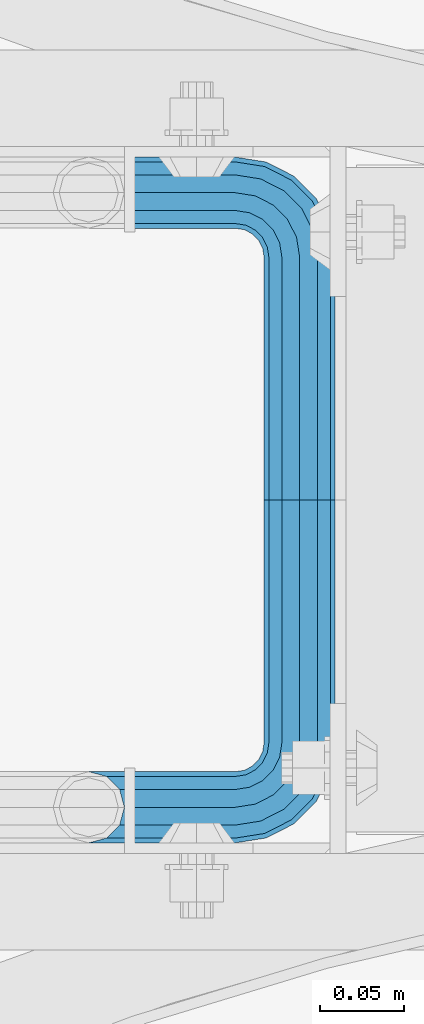
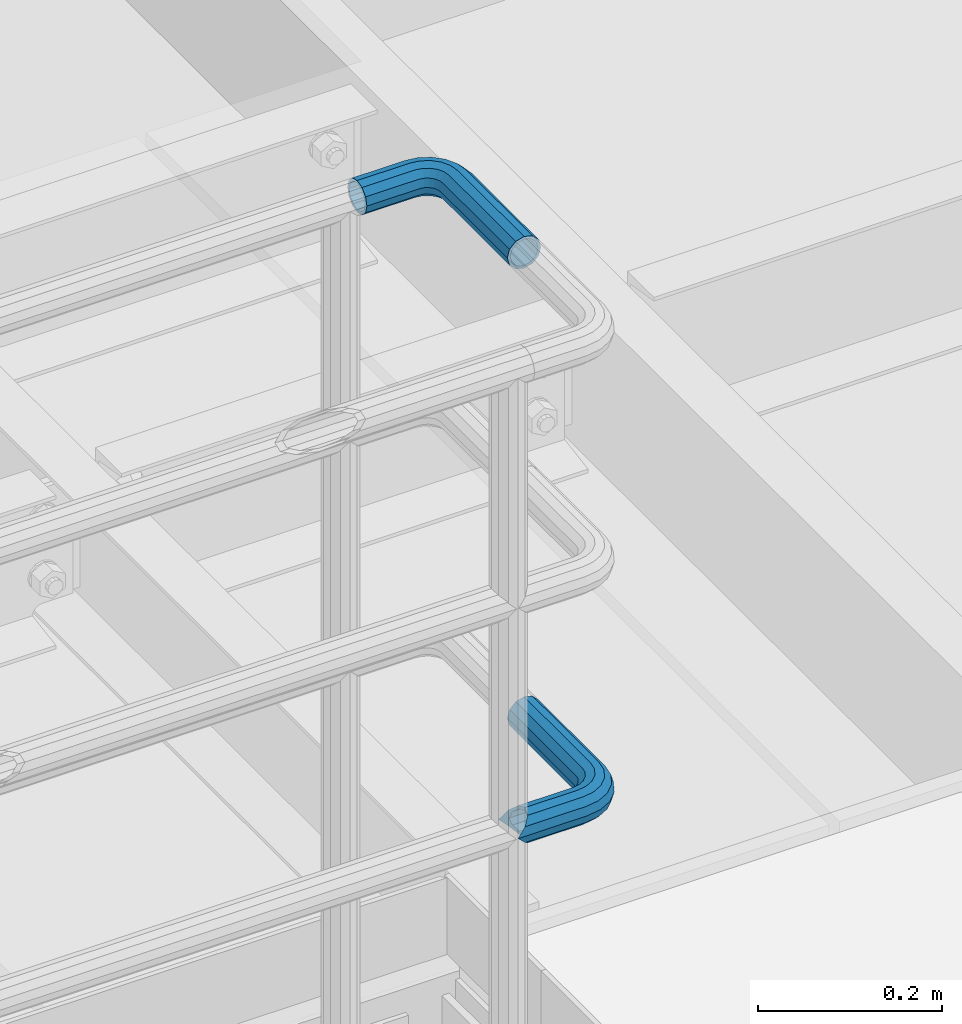
# One storey, part 1113 of 1876: 2 beams, 2 elements without a shape of their own.
"""IFC2X3 building model written with IfcOpenShell, lengths in millimetres."""

from ifc_helpers import new_model, si_unit, frame, origin_with_axes, place, context, subcontext, project, spatial, faceted_brep, material, type_object, element, aggregate, save


model = new_model("IFC2X3")

# Units and contexts
model_context = context("Model", 3, precision=1e-05, world=origin_with_axes())
body_context = subcontext(model_context, "Body", "Model", "MODEL_VIEW")
ifc_project = project(units=[si_unit("LENGTHUNIT", "METRE", prefix="MILLI"), si_unit("AREAUNIT", "SQUARE_METRE"), si_unit("VOLUMEUNIT", "CUBIC_METRE"), si_unit("MASSUNIT", "GRAM", prefix="KILO"), si_unit("TIMEUNIT", "SECOND"), si_unit("PLANEANGLEUNIT", "RADIAN"), si_unit("SOLIDANGLEUNIT", "STERADIAN"), si_unit("THERMODYNAMICTEMPERATUREUNIT", "DEGREE_CELSIUS"), si_unit("LUMINOUSINTENSITYUNIT", "LUMEN")], contexts=[model_context])

# Site, building, storey
site_placement = place(None, origin_with_axes())
site = spatial("IfcSite", under=ifc_project, at=site_placement, CompositionType="ELEMENT")
building_placement = place(site_placement, origin_with_axes())
building = spatial("IfcBuilding", under=site, at=building_placement, Name="Undefined", CompositionType="ELEMENT")
storey_placement = place(building_placement, origin_with_axes())
storey = spatial("IfcBuildingStorey", under=building, at=storey_placement, Name="Undefined", CompositionType="ELEMENT", Elevation=0.0)

# Assembly, beam
assembly_1_placement = place(storey_placement, origin_with_axes())
assembly_1 = element("IfcElementAssembly", 1, at=assembly_1_placement, inside=storey, Name="HANDRAIL", AssemblyPlace="NOTDEFINED", PredefinedType="RIGID_FRAME")
ifc_material = material()
beam_type = type_object("IfcBeamType", Name="PIPE1-1/4STD", PredefinedType="NOTDEFINED")
beam_1_placement = place(assembly_1_placement, frame((4696.96656849878, -11563.3144042962, 9090.025), z_axis=(0.0, 0.0, -1.0), x_axis=(0.0, 1.0, 0.0)))
beam_1 = element("IfcBeam", 2, at=beam_1_placement, type_object=beam_type, material=ifc_material, Name="HANDRAIL", ObjectType="PIPE1-1/4STD", context=body_context, shape_type="Brep", body=[
    faceted_brep([(9.09494701772928e-13, -21.0820000000003, 0.0), (0.0, -18.2575475625836, -10.5409999999993), (143.946846008301, -18.2575475625854, -10.5409999999993), (143.946846008301, -21.0820000000012, 0.0), (0.0, -10.5410000000002, -18.2575475625836), (143.946846008301, -10.5410000000011, -18.2575475625836), (-4.28826751885936e-09, 0.0, -21.0820000000003), (143.946846008301, -1.81898940354586e-12, -21.0820000000003), (0.0, 10.5410000000002, -18.2575475625836), (143.946846008301, 10.5409999999983, -18.2575475625836), (0.0, 18.2575475625836, -10.5409999999993), (143.946846008301, 18.2575475625817, -10.5409999999993), (9.09494701772928e-13, 21.0820000000003, 0.0), (143.946846008301, 21.0819999999985, 0.0), (0.0, 18.2575475625836, 10.5409999999993), (143.946846008301, 18.2575475625817, 10.5409999999993), (0.0, 10.5410000000002, 18.2575475625836), (143.946846008301, 10.5409999999983, 18.2575475625836), (0.0, 0.0, 21.0820000000003), (143.946846008301, -1.81898940354586e-12, 21.0820000000003), (0.0, -10.5410000000002, 18.2575475625836), (143.946846008301, -10.5410000000011, 18.2575475625836), (0.0, -18.2575475625836, 10.5409999999993), (143.946846008301, -18.2575475625854, 10.5409999999993), (0.0, -17.5259999999998, 0.0), (0.0, -15.1779612267264, 8.76300000000083), (143.946846008301, -15.1779612267273, 8.76300000000083), (143.946846008301, -17.5260000000017, 0.0), (0.0, -8.76299999999992, 15.1779612267255), (143.946846008301, -8.76300000000174, 15.1779612267255), (0.0, 0.0, 17.5259999999998), (143.946846008301, -1.81898940354586e-12, 17.5259999999998), (0.0, 8.76299999999992, 15.1779612267255), (143.946846008301, 8.76299999999901, 15.1779612267255), (0.0, 15.1779612267264, 8.76300000000083), (143.946846008301, 15.1779612267246, 8.76300000000083), (0.0, 17.5259999999998, 0.0), (143.946846008301, 17.5259999999989, 0.0), (0.0, 15.1779612267264, -8.76300000000083), (143.946846008301, 15.1779612267246, -8.76300000000083), (0.0, 8.76299999999992, -15.1779612267255), (143.946846008301, 8.76299999999901, -15.1779612267255), (0.0, 0.0, -17.5259999999998), (143.946846008301, -1.81898940354586e-12, -17.5259999999998), (0.0, -8.76299999999992, -15.1779612267255), (143.946846008301, -8.76300000000174, -15.1779612267255), (0.0, -15.1779612267264, -8.76300000000083), (143.946846008301, -15.1779612267273, -8.76300000000083), (149.205696747053, -21.9149201310092, 0.0), (150.078500550018, -19.2287062354389, 10.5409999999993), (152.46304488476, -11.8898333927427, 18.2575475625836), (155.720393022468, -1.86474665447531, 21.0820000000003), (158.977741160175, 8.1603400837912, 18.2575475625836), (161.362285494917, 15.4992129264883, 10.5409999999993), (162.235089297883, 18.1854268220586, 0.0), (161.362285494917, 15.4992129264883, -10.5409999999993), (158.977741160175, 8.1603400837912, -18.2575475625836), (155.720393022468, -1.86474665447531, -21.0820000000003), (152.46304488476, -11.8898333927427, -18.2575475625836), (150.078500550018, -19.2287062354389, -10.5409999999993), (161.136224865884, 14.8034698501133, 0.0), (160.410640981492, 12.570352274277, 8.76300000000083), (158.428308944176, 6.46936159781853, 15.1779612267255), (155.720393022468, -1.86474665447531, 17.5259999999998), (153.012477100759, -10.1988549067692, 15.1779612267255), (151.030145063443, -16.2998455832276, 8.76300000000083), (150.304561179051, -18.5329631590639, 0.0), (151.030145063443, -16.2998455832276, -8.76300000000083), (153.012477100759, -10.1988549067692, -15.1779612267255), (155.720393022468, -1.86474665447531, -17.5259999999998), (158.428308944176, 6.46936159781853, -15.1779612267255), (160.410640981492, 12.570352274277, -8.76300000000083), (172.537307568173, 1.25139591480547, 18.2575475625836), (177.072980424075, 7.49421403083761, 10.5409999999993), (166.341463223758, -7.27645222290084, 21.0820000000003), (160.145618879342, -15.8043003606062, 18.2575475625836), (155.609946023442, -22.0471184766393, 10.5409999999993), (153.949774534927, -24.3321484983126, 0.0), (155.609946023442, -22.0471184766393, -10.5409999999993), (160.145618879342, -15.8043003606062, -18.2575475625836), (166.341463223758, -7.27645222290084, -21.0820000000003), (172.537307568173, 1.25139591480547, -18.2575475625836), (177.072980424075, 7.49421403083761, -10.5409999999993), (178.733151912589, 9.77924405251179, 0.0), (175.262844992696, 5.00277634948452, -8.76300000000083), (176.642987555437, 6.90237962051378, 0.0), (171.492225389597, -0.187036301193075, -15.1779612267255), (166.341463223758, -7.27645222290084, -17.5259999999998), (161.190701057918, -14.3658681446077, -15.1779612267255), (157.42008145482, -19.5556807952853, -8.76300000000083), (156.03993889208, -21.4552840663155, 0.0), (157.42008145482, -19.5556807952853, 8.76300000000083), (161.190701057918, -14.3658681446077, 15.1779612267255), (166.341463223758, -7.27645222290084, 17.5259999999998), (171.492225389597, -0.187036301193075, 15.1779612267255), (175.262844992696, 5.00277634948452, 8.76300000000083), (183.298240397229, -9.50953691424911, 18.2575475625836), (189.541058513261, -4.97386405834823, 10.5409999999993), (174.770392259523, -15.7053812586646, 21.0820000000003), (166.242544121817, -21.901225603081, 18.2575475625836), (159.999726005784, -26.4368984589819, 10.5409999999993), (157.714695984112, -28.0970699474974, 0.0), (159.999726005784, -26.4368984589819, -10.5409999999993), (166.242544121817, -21.901225603081, -18.2575475625836), (174.770392259523, -15.7053812586646, -21.0820000000003), (183.298240397229, -9.50953691424911, -18.2575475625836), (189.541058513261, -4.97386405834823, -10.5409999999993), (191.826088534934, -3.31369256983271, 0.0), (187.049620831907, -6.78399948972674, -8.76300000000083), (188.949224102937, -5.4038569269851, 0.0), (181.859808181231, -10.5546190928253, -15.1779612267255), (174.770392259523, -15.7053812586646, -17.5259999999998), (167.680976337815, -20.8561434245048, -15.1779612267255), (162.491163687138, -24.6267630276034, -8.76300000000083), (160.591560416109, -26.006905590345, 0.0), (162.491163687138, -24.6267630276034, 8.76300000000083), (167.680976337815, -20.8561434245048, 15.1779612267255), (174.770392259523, -15.7053812586646, 17.5259999999998), (181.859808181231, -10.5546190928253, 15.1779612267255), (187.049620831907, -6.78399948972674, 8.76300000000083), (190.207184566216, -23.0691033222465, 18.2575475625836), (197.546057408912, -20.6845589875047, 10.5409999999993), (180.182097827948, -26.3264514599541, 21.0820000000003), (170.157011089683, -29.5837995976626, 18.2575475625836), (162.818138246987, -31.9683439324044, 10.5409999999993), (160.131924351415, -32.8411477353702, 0.0), (162.818138246987, -31.9683439324044, -10.5409999999993), (170.157011089683, -29.5837995976626, -18.2575475625836), (180.182097827948, -26.3264514599541, -21.0820000000003), (190.207184566216, -23.0691033222465, -18.2575475625836), (197.546057408912, -20.6845589875047, -10.5409999999993), (200.232271304483, -19.8117551845389, 0.0), (194.617196756701, -21.6362035009297, -8.76300000000083), (196.850314332538, -20.9106196165367, 0.0), (188.516206080243, -23.6185355382449, -15.1779612267255), (180.182097827948, -26.3264514599541, -17.5259999999998), (171.847989575655, -29.0343673816633, -15.1779612267255), (165.746998899196, -31.0166994189794, -8.76300000000083), (163.513881323361, -31.7422833033725, 0.0), (165.746998899196, -31.0166994189794, 8.76300000000083), (171.847989575655, -29.0343673816633, 15.1779612267255), (180.182097827948, -26.3264514599541, 17.5259999999998), (188.516206080243, -23.6185355382449, 15.1779612267255), (194.617196756701, -21.6362035009297, 8.76300000000083), (171.505844482424, -38.0999984741229, -18.2575475625836), (163.78929691984, -38.0999984741229, -10.5409999999993), (182.046844482424, -38.099998474122, -21.0820000000003), (192.587844482425, -38.099998474122, -18.2575475625836), (200.304392045007, -38.099998474122, -10.5409999999993), (203.128844482424, -38.099998474122, 0.0), (200.304392045007, -38.099998474122, 10.5409999999993), (192.587844482425, -38.099998474122, 18.2575475625836), (182.046844482424, -38.099998474122, 21.0820000000003), (171.505844482424, -38.0999984741229, 18.2575475625836), (163.78929691984, -38.0999984741229, 10.5409999999993), (160.964844482422, -38.0999984741229, 0.0), (197.224805709149, -38.099998474122, -8.76300000000083), (199.572844482424, -38.099998474122, 0.0), (190.809844482425, -38.099998474122, -15.1779612267255), (182.046844482424, -38.099998474122, -17.5259999999998), (173.283844482423, -38.099998474122, -15.1779612267255), (166.868883255698, -38.0999984741229, -8.76300000000083), (164.520844482422, -38.0999984741229, 0.0), (166.868883255698, -38.0999984741229, 8.76300000000083), (173.283844482423, -38.099998474122, 15.1779612267255), (182.046844482424, -38.099998474122, 17.5259999999998), (190.809844482425, -38.099998474122, 15.1779612267255), (197.224805709149, -38.099998474122, 8.76300000000083), (163.789296919838, -103.933624267578, -10.5409999999993), (160.964844482422, -103.933624267578, 0.0), (171.505844482423, -103.933624267578, -18.2575475625836), (182.046844482422, -103.933624267578, -21.0820000000003), (192.587844482421, -103.933624267578, -18.2575475625836), (200.304392045005, -103.933624267578, -10.5409999999993), (203.128844482422, -103.933624267578, 0.0), (200.304392045005, -103.933624267578, 10.5409999999993), (192.587844482421, -103.933624267578, 18.2575475625836), (182.046844482422, -103.933624267578, 21.0820000000003), (171.505844482423, -103.933624267578, 18.2575475625836), (163.789296919838, -103.933624267578, 10.5409999999993), (166.868883255696, -103.933624267578, 8.76300000000083), (164.520844482422, -103.933624267578, 0.0), (173.283844482421, -103.933624267578, 15.1779612267255), (182.046844482422, -103.933624267578, 17.5259999999998), (190.809844482423, -103.933624267578, 15.1779612267255), (197.224805709147, -103.933624267578, 8.76300000000083), (199.572844482422, -103.933624267578, 0.0), (197.224805709147, -103.933624267578, -8.76300000000083), (190.809844482423, -103.933624267578, -15.1779612267255), (182.046844482422, -103.933624267578, -17.5259999999998), (173.283844482421, -103.933624267578, -15.1779612267255), (166.868883255696, -103.933624267578, -8.76300000000083)], [[[0, 1, 2, 3]], [[1, 4, 5, 2]], [[4, 6, 7, 5]], [[6, 8, 9, 7]], [[8, 10, 11, 9]], [[10, 12, 13, 11]], [[12, 14, 15, 13]], [[14, 16, 17, 15]], [[16, 18, 19, 17]], [[18, 20, 21, 19]], [[20, 22, 23, 21]], [[22, 0, 3, 23]], [[24, 25, 26, 27]], [[25, 28, 29, 26]], [[28, 30, 31, 29]], [[30, 32, 33, 31]], [[32, 34, 35, 33]], [[34, 36, 37, 35]], [[36, 38, 39, 37]], [[38, 40, 41, 39]], [[40, 42, 43, 41]], [[42, 44, 45, 43]], [[44, 46, 47, 45]], [[46, 24, 27, 47]], [[22, 20, 18, 16, 14, 12, 10, 8, 6, 4, 1, 0], [46, 44, 42, 40, 38, 36, 34, 32, 30, 28, 25, 24]], [[23, 3, 48, 49]], [[21, 23, 49, 50]], [[19, 21, 50, 51]], [[17, 19, 51, 52]], [[15, 17, 52, 53]], [[13, 15, 53, 54]], [[11, 13, 54, 55]], [[9, 11, 55, 56]], [[7, 9, 56, 57]], [[5, 7, 57, 58]], [[2, 5, 58, 59]], [[3, 2, 59, 48]], [[35, 37, 60, 61]], [[33, 35, 61, 62]], [[31, 33, 62, 63]], [[29, 31, 63, 64]], [[26, 29, 64, 65]], [[27, 26, 65, 66]], [[47, 27, 66, 67]], [[45, 47, 67, 68]], [[43, 45, 68, 69]], [[41, 43, 69, 70]], [[39, 41, 70, 71]], [[37, 39, 71, 60]], [[52, 72, 73, 53]], [[51, 74, 72, 52]], [[50, 75, 74, 51]], [[49, 76, 75, 50]], [[48, 77, 76, 49]], [[59, 78, 77, 48]], [[58, 79, 78, 59]], [[57, 80, 79, 58]], [[56, 81, 80, 57]], [[55, 82, 81, 56]], [[54, 83, 82, 55]], [[53, 73, 83, 54]], [[71, 84, 85, 60]], [[70, 86, 84, 71]], [[69, 87, 86, 70]], [[68, 88, 87, 69]], [[67, 89, 88, 68]], [[66, 90, 89, 67]], [[65, 91, 90, 66]], [[64, 92, 91, 65]], [[63, 93, 92, 64]], [[62, 94, 93, 63]], [[61, 95, 94, 62]], [[60, 85, 95, 61]], [[72, 96, 97, 73]], [[74, 98, 96, 72]], [[75, 99, 98, 74]], [[76, 100, 99, 75]], [[77, 101, 100, 76]], [[78, 102, 101, 77]], [[79, 103, 102, 78]], [[80, 104, 103, 79]], [[81, 105, 104, 80]], [[82, 106, 105, 81]], [[83, 107, 106, 82]], [[73, 97, 107, 83]], [[84, 108, 109, 85]], [[86, 110, 108, 84]], [[87, 111, 110, 86]], [[88, 112, 111, 87]], [[89, 113, 112, 88]], [[90, 114, 113, 89]], [[91, 115, 114, 90]], [[92, 116, 115, 91]], [[93, 117, 116, 92]], [[94, 118, 117, 93]], [[95, 119, 118, 94]], [[85, 109, 119, 95]], [[96, 120, 121, 97]], [[98, 122, 120, 96]], [[99, 123, 122, 98]], [[100, 124, 123, 99]], [[101, 125, 124, 100]], [[102, 126, 125, 101]], [[103, 127, 126, 102]], [[104, 128, 127, 103]], [[105, 129, 128, 104]], [[106, 130, 129, 105]], [[107, 131, 130, 106]], [[97, 121, 131, 107]], [[108, 132, 133, 109]], [[110, 134, 132, 108]], [[111, 135, 134, 110]], [[112, 136, 135, 111]], [[113, 137, 136, 112]], [[114, 138, 137, 113]], [[115, 139, 138, 114]], [[116, 140, 139, 115]], [[117, 141, 140, 116]], [[118, 142, 141, 117]], [[119, 143, 142, 118]], [[109, 133, 143, 119]], [[127, 144, 145, 126]], [[128, 146, 144, 127]], [[129, 147, 146, 128]], [[130, 148, 147, 129]], [[131, 149, 148, 130]], [[121, 150, 149, 131]], [[120, 151, 150, 121]], [[122, 152, 151, 120]], [[123, 153, 152, 122]], [[124, 154, 153, 123]], [[125, 155, 154, 124]], [[126, 145, 155, 125]], [[132, 156, 157, 133]], [[134, 158, 156, 132]], [[135, 159, 158, 134]], [[136, 160, 159, 135]], [[137, 161, 160, 136]], [[138, 162, 161, 137]], [[139, 163, 162, 138]], [[140, 164, 163, 139]], [[141, 165, 164, 140]], [[142, 166, 165, 141]], [[143, 167, 166, 142]], [[133, 157, 167, 143]], [[155, 145, 168, 169]], [[145, 144, 170, 168]], [[144, 146, 171, 170]], [[146, 147, 172, 171]], [[147, 148, 173, 172]], [[148, 149, 174, 173]], [[149, 150, 175, 174]], [[150, 151, 176, 175]], [[151, 152, 177, 176]], [[152, 153, 178, 177]], [[153, 154, 179, 178]], [[154, 155, 169, 179]], [[162, 163, 180, 181]], [[163, 164, 182, 180]], [[164, 165, 183, 182]], [[165, 166, 184, 183]], [[166, 167, 185, 184]], [[167, 157, 186, 185]], [[157, 156, 187, 186]], [[156, 158, 188, 187]], [[158, 159, 189, 188]], [[159, 160, 190, 189]], [[160, 161, 191, 190]], [[161, 162, 181, 191]], [[170, 171, 172, 173, 174, 175, 176, 177, 178, 179, 169, 168], [182, 183, 184, 185, 186, 187, 188, 189, 190, 191, 181, 180]]]),
])
aggregate(assembly_1, [beam_1])

assembly_2_placement = place(storey_placement, origin_with_axes())
assembly_2 = element("IfcElementAssembly", 3, at=assembly_2_placement, inside=storey, Name="HANDRAIL", AssemblyPlace="NOTDEFINED", PredefinedType="RIGID_FRAME")
beam_2_placement = place(assembly_2_placement, frame((4696.96656849878, -11563.3144042962, 8480.425), z_axis=(0.0, 0.0, -1.0), x_axis=(0.0, -1.0, 0.0)))
beam_2 = element("IfcBeam", 4, at=beam_2_placement, type_object=beam_type, material=ifc_material, Name="HANDRAIL", ObjectType="PIPE1-1/4STD", context=body_context, shape_type="Brep", body=[
    faceted_brep([(192.659041992189, 106.710451704997, 18.2575475625836), (192.659048095087, 106.710451704997, 13.3999551238248), (190.881041992188, 106.234036405587, 15.1779612267255), (182.118041992188, 103.88599926758, 17.5259999999998), (182.118041992188, 103.88599926758, 21.0820000000003), (173.355041992188, 106.234039676121, 15.1779612267255), (171.577048095089, 106.710451704997, 13.3999673296257), (171.577041992188, 106.710451704997, 18.2575475625836), (163.860494429604, 114.42699926758, 10.5409999999993), (163.860494429604, 114.42699926758, -10.5409999999993), (161.036041992187, 124.968002319336, 0.0), (166.940080765462, 111.347419034623, 8.76300000000083), (164.592041992188, 113.695457807897, 0.0), (166.940080765462, 111.347419034623, -8.76300000000083), (171.577048095089, 106.710451704997, -13.3999673296257), (171.577041992188, 106.710451704997, -18.2575475625836), (182.118041992188, 103.88599926758, -17.5259999999998), (182.118041992188, 103.88599926758, -21.0820000000003), (173.355041992188, 106.234039676121, -15.1779612267255), (192.659048095087, 106.710451704997, -13.3999551238248), (192.659041992189, 106.710451704997, -18.2575475625836), (190.881041992188, 106.234036405587, -15.1779612267255), (203.200048095088, 124.96799926758, 0.0), (200.375589554771, 114.42699926758, -10.5409999999993), (200.375589554771, 114.42699926758, 10.5409999999993), (197.296003218913, 111.347406828822, -8.76300000000083), (199.644041992187, 113.695445602096, 0.0), (197.296003218913, 111.347406828822, 8.76300000000083), (0.0, -18.2575475625836, -10.5409999999993), (0.0, -10.5410000000002, -18.2575475625836), (144.018043518066, -10.5409999999983, -18.2575475625836), (144.018043518066, -18.2575475625817, -10.5409999999993), (-4.28826751885936e-09, 0.0, -21.0820000000003), (144.018043518066, 1.81898940354586e-12, -21.0820000000003), (0.0, 10.5410000000002, -18.2575475625836), (144.018043518066, 10.5410000000011, -18.2575475625836), (0.0, 18.2575475625836, -10.5409999999993), (144.018043518066, 18.2575475625854, -10.5409999999993), (9.09494701772928e-13, 21.0820000000003, 0.0), (144.018043518066, 21.0820000000012, 0.0), (0.0, 18.2575475625836, 10.5409999999993), (144.018043518066, 18.2575475625854, 10.5409999999993), (0.0, 10.5410000000002, 18.2575475625836), (144.018043518066, 10.5410000000011, 18.2575475625836), (0.0, 0.0, 21.0820000000003), (144.018043518066, 1.81898940354586e-12, 21.0820000000003), (0.0, -10.5410000000002, 18.2575475625836), (144.018043518066, -10.5409999999983, 18.2575475625836), (0.0, -18.2575475625836, 10.5409999999993), (144.018043518066, -18.2575475625817, 10.5409999999993), (9.09494701772928e-13, -21.0820000000003, 0.0), (144.018043518066, -21.0819999999985, 0.0), (162.306286807647, -18.1854268220595, 0.0), (161.433483004681, -15.4992129264883, 10.5409999999993), (159.048938669939, -8.16034008379211, 18.2575475625836), (155.791590532232, 1.86474665447531, 21.0820000000003), (152.534242394526, 11.8898333927418, 18.2575475625836), (150.149698059784, 19.228706235438, 10.5409999999993), (149.276894256818, 21.9149201310092, 0.0), (150.149698059784, 19.2287062354389, -10.5409999999993), (152.534242394526, 11.8898333927418, -18.2575475625836), (155.791590532232, 1.86474665447531, -21.0820000000003), (159.048938669939, -8.16034008379211, -18.2575475625836), (161.433483004681, -15.4992129264883, -10.5409999999993), (163.860494429606, 38.0999984741229, -10.5409999999993), (161.036041992189, 38.0999984741229, 0.0), (163.860494429606, 38.0999984741229, 10.5409999999993), (171.57704199219, 38.0999984741229, 18.2575475625836), (182.118041992189, 38.099998474122, 21.0820000000003), (192.65904199219, 38.099998474122, 18.2575475625836), (200.375589554773, 38.099998474122, 10.5409999999993), (203.200041992188, 38.0999984741229, 0.0), (182.118041992189, 38.099998474122, -21.0820000000003), (171.57704199219, 38.0999984741229, -18.2575475625836), (192.65904199219, 38.099998474122, -18.2575475625836), (200.375589554773, 38.099998474122, -10.5409999999993), (162.889335756752, 31.9683439324062, -10.5409999999993), (170.228208599448, 29.5837995976653, -18.2575475625836), (160.203121861181, 32.841147735372, 0.0), (162.889335756752, 31.9683439324062, 10.5409999999993), (170.228208599448, 29.5837995976653, 18.2575475625836), (180.253295337716, 26.3264514599587, 21.0820000000003), (190.278382075983, 23.069103322252, 18.2575475625836), (197.617254918679, 20.6845589875102, 10.5409999999993), (200.303468814251, 19.8117551845444, 0.0), (197.617254918679, 20.6845589875102, -10.5409999999993), (190.278382075983, 23.069103322252, -18.2575475625836), (180.253295337716, 26.3264514599587, -21.0820000000003), (166.313741631582, 21.9012256030801, -18.2575475625836), (174.841589769288, 15.7053812586637, -21.0820000000003), (160.07092351555, 26.436898458981, -10.5409999999993), (157.785893493878, 28.0970699474965, 0.0), (160.07092351555, 26.436898458981, 10.5409999999993), (166.313741631582, 21.9012256030801, 18.2575475625836), (174.841589769288, 15.7053812586637, 21.0820000000003), (183.369437906993, 9.50953691424729, 18.2575475625836), (189.612256023025, 4.97386405834641, 10.5409999999993), (191.897286044699, 3.31369256983089, 0.0), (189.612256023025, 4.97386405834641, -10.5409999999993), (183.369437906993, 9.50953691424729, -18.2575475625836), (166.412660733527, 7.27645222290266, -21.0820000000003), (172.608505077944, -1.25139591480183, -18.2575475625836), (160.216816389111, 15.8043003606081, -18.2575475625836), (155.681143533209, 22.0471184766402, -10.5409999999993), (154.020972044695, 24.3321484983135, 0.0), (155.681143533209, 22.0471184766402, 10.5409999999993), (160.216816389111, 15.8043003606081, 18.2575475625836), (166.412660733527, 7.27645222290266, 21.0820000000003), (172.608505077944, -1.25139591480183, 18.2575475625836), (177.144177933844, -7.49421403083397, 10.5409999999993), (178.80434942236, -9.77924405250724, 0.0), (177.144177933844, -7.49421403083397, -10.5409999999993), (0.0, -15.1779612267264, -8.76300000000083), (0.0, -8.76299999999992, -15.1779612267255), (0.0, 0.0, -17.5259999999998), (0.0, 8.76299999999992, -15.1779612267255), (0.0, 15.1779612267264, -8.76300000000083), (0.0, 17.5259999999998, 0.0), (0.0, 15.1779612267264, 8.76300000000083), (0.0, 8.76299999999992, 15.1779612267255), (0.0, 0.0, 17.5259999999998), (0.0, -8.76299999999992, 15.1779612267255), (0.0, -15.1779612267264, 8.76300000000083), (0.0, -17.5259999999998, 0.0), (144.018043518066, -8.7629999999981, 15.1779612267255), (144.018043518066, -15.1779612267246, 8.76300000000083), (144.018043518066, -17.5259999999989, 0.0), (144.018043518066, -15.1779612267246, -8.76300000000083), (144.018043518066, -8.76299999999901, -15.1779612267255), (144.018043518066, 1.81898940354586e-12, -17.5259999999998), (144.018043518066, 8.76300000000174, -15.1779612267255), (144.018043518066, 15.1779612267273, -8.76300000000083), (144.018043518066, 17.5260000000017, 0.0), (144.018043518066, 15.1779612267273, 8.76300000000083), (144.018043518066, 8.76300000000174, 15.1779612267255), (144.018043518066, 1.81898940354586e-12, 17.5259999999998), (155.791590532232, 1.86474665447531, 17.5259999999998), (158.49950645394, -6.46936159781944, 15.1779612267255), (160.481838491256, -12.5703522742779, 8.76300000000083), (161.207422375648, -14.8034698501133, 0.0), (160.481838491256, -12.5703522742779, -8.76300000000083), (158.49950645394, -6.46936159781944, -15.1779612267255), (155.791590532232, 1.86474665447531, -17.5259999999998), (153.083674610523, 10.1988549067692, -15.1779612267255), (151.101342573209, 16.2998455832276, -8.76300000000083), (150.375758688817, 18.5329631590639, 0.0), (151.101342573209, 16.2998455832276, 8.76300000000083), (153.083674610523, 10.1988549067692, 15.1779612267255), (161.261898567687, 14.3658681446095, 15.1779612267255), (166.412660733527, 7.27645222290266, 17.5259999999998), (157.491278964588, 19.5556807952871, 8.76300000000083), (156.111136401847, 21.4552840663164, 0.0), (157.491278964588, 19.5556807952871, -8.76300000000083), (161.261898567687, 14.3658681446095, -15.1779612267255), (166.412660733527, 7.27645222290266, -17.5259999999998), (171.563422899368, 0.187036301196713, -15.1779612267255), (175.334042502465, -5.00277634948088, -8.76300000000083), (176.714185065208, -6.90237962051015, 0.0), (175.334042502465, -5.00277634948088, 8.76300000000083), (171.563422899368, 0.187036301196713, 15.1779612267255), (174.841589769288, 15.7053812586637, 17.5259999999998), (181.931005690994, 10.5546190928235, 15.1779612267255), (167.752173847581, 20.8561434245039, 15.1779612267255), (162.562361196904, 24.6267630276025, 8.76300000000083), (160.662757925875, 26.0069055903441, 0.0), (162.562361196904, 24.6267630276025, -8.76300000000083), (167.752173847581, 20.8561434245039, -15.1779612267255), (174.841589769288, 15.7053812586637, -17.5259999999998), (181.931005690994, 10.5546190928235, -15.1779612267255), (187.120818341671, 6.78399948972492, -8.76300000000083), (189.020421612702, 5.40385692698328, 0.0), (187.120818341671, 6.78399948972492, 8.76300000000083), (188.587403590011, 23.6185355382504, 15.1779612267255), (194.688394266468, 21.6362035009352, 8.76300000000083), (180.253295337716, 26.3264514599587, 17.5259999999998), (171.919187085421, 29.0343673816669, 15.1779612267255), (165.818196408964, 31.0166994189813, 8.76300000000083), (163.585078833126, 31.7422833033743, 0.0), (165.818196408964, 31.0166994189813, -8.76300000000083), (171.919187085421, 29.0343673816669, -15.1779612267255), (180.253295337716, 26.3264514599587, -17.5259999999998), (188.587403590011, 23.6185355382504, -15.1779612267255), (194.688394266468, 21.6362035009352, -8.76300000000083), (196.921511842305, 20.9106196165421, 0.0), (197.296003218915, 38.099998474122, 8.76300000000083), (199.644041992187, 38.0999984741229, 0.0), (190.88104199219, 38.099998474122, 15.1779612267255), (182.118041992189, 38.099998474122, 17.5259999999998), (173.355041992188, 38.099998474122, 15.1779612267255), (166.940080765464, 38.0999984741229, 8.76300000000083), (164.592041992189, 38.0999984741229, 0.0), (166.940080765464, 38.0999984741229, -8.76300000000083), (173.355041992188, 38.0999984741229, -15.1779612267255), (182.118041992189, 38.099998474122, -17.5259999999998), (190.88104199219, 38.099998474122, -15.1779612267255), (197.296003218915, 38.099998474122, -8.76300000000083)], [[[0, 1, 2, 3, 4]], [[4, 3, 5, 6, 7]], [[8, 9, 10]], [[7, 6, 11, 12, 13, 14, 15, 9, 8]], [[16, 17, 15, 14, 18]], [[19, 20, 17, 16, 21]], [[22, 23, 24]], [[24, 23, 20, 19, 25, 26, 27, 1, 0]], [[28, 29, 30, 31]], [[29, 32, 33, 30]], [[32, 34, 35, 33]], [[34, 36, 37, 35]], [[36, 38, 39, 37]], [[38, 40, 41, 39]], [[40, 42, 43, 41]], [[42, 44, 45, 43]], [[44, 46, 47, 45]], [[46, 48, 49, 47]], [[48, 50, 51, 49]], [[49, 51, 52, 53]], [[47, 49, 53, 54]], [[45, 47, 54, 55]], [[43, 45, 55, 56]], [[41, 43, 56, 57]], [[39, 41, 57, 58]], [[37, 39, 58, 59]], [[35, 37, 59, 60]], [[33, 35, 60, 61]], [[30, 33, 61, 62]], [[31, 30, 62, 63]], [[64, 65, 10, 9]], [[65, 66, 8, 10]], [[66, 67, 7, 8]], [[67, 68, 4, 7]], [[68, 69, 0, 4]], [[69, 70, 24, 0]], [[70, 71, 22, 24]], [[72, 73, 15, 17]], [[74, 72, 17, 20]], [[75, 74, 20, 23]], [[71, 75, 23, 22]], [[73, 64, 9, 15]], [[76, 64, 73, 77]], [[78, 65, 64, 76]], [[79, 66, 65, 78]], [[80, 67, 66, 79]], [[81, 68, 67, 80]], [[82, 69, 68, 81]], [[83, 70, 69, 82]], [[84, 71, 70, 83]], [[85, 75, 71, 84]], [[86, 74, 75, 85]], [[87, 72, 74, 86]], [[77, 73, 72, 87]], [[88, 77, 87, 89]], [[90, 76, 77, 88]], [[91, 78, 76, 90]], [[92, 79, 78, 91]], [[93, 80, 79, 92]], [[94, 81, 80, 93]], [[95, 82, 81, 94]], [[96, 83, 82, 95]], [[97, 84, 83, 96]], [[98, 85, 84, 97]], [[99, 86, 85, 98]], [[89, 87, 86, 99]], [[100, 89, 99, 101]], [[102, 88, 89, 100]], [[103, 90, 88, 102]], [[104, 91, 90, 103]], [[105, 92, 91, 104]], [[106, 93, 92, 105]], [[107, 94, 93, 106]], [[108, 95, 94, 107]], [[109, 96, 95, 108]], [[110, 97, 96, 109]], [[111, 98, 97, 110]], [[101, 99, 98, 111]], [[62, 101, 111, 63]], [[61, 100, 101, 62]], [[60, 102, 100, 61]], [[59, 103, 102, 60]], [[58, 104, 103, 59]], [[57, 105, 104, 58]], [[56, 106, 105, 57]], [[55, 107, 106, 56]], [[54, 108, 107, 55]], [[53, 109, 108, 54]], [[52, 110, 109, 53]], [[63, 111, 110, 52]], [[51, 31, 63, 52]], [[50, 28, 31, 51]], [[48, 46, 44, 42, 40, 38, 36, 34, 32, 29, 28, 50], [112, 113, 114, 115, 116, 117, 118, 119, 120, 121, 122, 123]], [[122, 121, 124, 125]], [[123, 122, 125, 126]], [[112, 123, 126, 127]], [[113, 112, 127, 128]], [[114, 113, 128, 129]], [[115, 114, 129, 130]], [[116, 115, 130, 131]], [[117, 116, 131, 132]], [[118, 117, 132, 133]], [[119, 118, 133, 134]], [[120, 119, 134, 135]], [[121, 120, 135, 124]], [[124, 135, 136, 137]], [[125, 124, 137, 138]], [[126, 125, 138, 139]], [[127, 126, 139, 140]], [[128, 127, 140, 141]], [[129, 128, 141, 142]], [[130, 129, 142, 143]], [[131, 130, 143, 144]], [[132, 131, 144, 145]], [[133, 132, 145, 146]], [[134, 133, 146, 147]], [[135, 134, 147, 136]], [[147, 148, 149, 136]], [[146, 150, 148, 147]], [[145, 151, 150, 146]], [[144, 152, 151, 145]], [[143, 153, 152, 144]], [[142, 154, 153, 143]], [[141, 155, 154, 142]], [[140, 156, 155, 141]], [[139, 157, 156, 140]], [[138, 158, 157, 139]], [[137, 159, 158, 138]], [[136, 149, 159, 137]], [[149, 160, 161, 159]], [[148, 162, 160, 149]], [[150, 163, 162, 148]], [[151, 164, 163, 150]], [[152, 165, 164, 151]], [[153, 166, 165, 152]], [[154, 167, 166, 153]], [[155, 168, 167, 154]], [[156, 169, 168, 155]], [[157, 170, 169, 156]], [[158, 171, 170, 157]], [[159, 161, 171, 158]], [[161, 172, 173, 171]], [[160, 174, 172, 161]], [[162, 175, 174, 160]], [[163, 176, 175, 162]], [[164, 177, 176, 163]], [[165, 178, 177, 164]], [[166, 179, 178, 165]], [[167, 180, 179, 166]], [[168, 181, 180, 167]], [[169, 182, 181, 168]], [[170, 183, 182, 169]], [[171, 173, 183, 170]], [[173, 184, 185, 183]], [[172, 186, 184, 173]], [[174, 187, 186, 172]], [[175, 188, 187, 174]], [[176, 189, 188, 175]], [[177, 190, 189, 176]], [[178, 191, 190, 177]], [[179, 192, 191, 178]], [[180, 193, 192, 179]], [[181, 194, 193, 180]], [[182, 195, 194, 181]], [[183, 185, 195, 182]], [[195, 185, 26, 25]], [[21, 194, 195, 25, 19]], [[193, 194, 21, 16]], [[192, 193, 16, 18]], [[13, 191, 192, 18, 14]], [[190, 191, 13, 12]], [[189, 190, 12, 11]], [[188, 189, 11, 6, 5]], [[187, 188, 5, 3]], [[186, 187, 3, 2]], [[184, 186, 2, 1, 27]], [[185, 184, 27, 26]]]),
])
aggregate(assembly_2, [beam_2])

save(model, "model.ifc")
